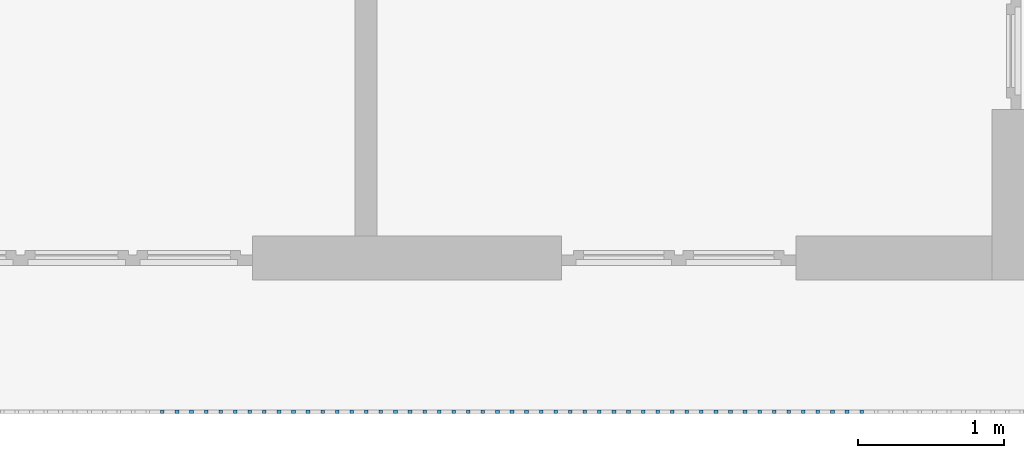
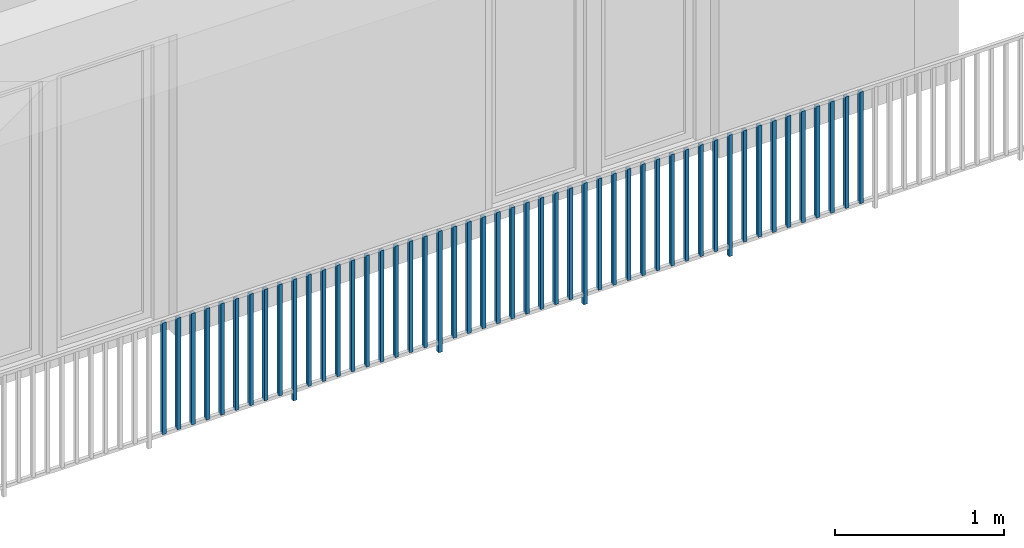
# One storey, part 42 of 54: 49 building element parts, 1 element without a shape of its own.
"""IFC4 building model written with IfcOpenShell, lengths in metres."""

from ifc_helpers import new_model, entity, si_unit, converted_unit, derived_unit, direction, frame, origin_with_axes, place, context, subcontext, project, spatial, polygons, material, type_object, element, aggregate, save


model = new_model("IFC4")

# Units and contexts
model_context = context("Model", 3, precision=1e-05, world=origin_with_axes(), true_north=direction((0.0, 1.0)))
body_context = subcontext(model_context, "Body", "Model", "MODEL_VIEW")
ifc_project = project(units=[si_unit("LENGTHUNIT", "METRE"), si_unit("AREAUNIT", "SQUARE_METRE"), si_unit("VOLUMEUNIT", "CUBIC_METRE"), converted_unit("PLANEANGLEUNIT", "DEGREE", entity("IfcPlaneAngleMeasure", 0.0174532925199), si_unit("PLANEANGLEUNIT", "RADIAN"), dimensions=[0, 0, 0, 0, 0, 0, 0]), converted_unit("TIMEUNIT", "Year", entity("IfcTimeMeasure", 31556926.0), si_unit("TIMEUNIT", "SECOND"), dimensions=[0, 0, 1, 0, 0, 0, 0]), si_unit("MASSUNIT", "GRAM", prefix="KILO"), si_unit("THERMODYNAMICTEMPERATUREUNIT", "DEGREE_CELSIUS"), si_unit("LUMINOUSINTENSITYUNIT", "LUMEN"), si_unit("ENERGYUNIT", "JOULE", prefix="MEGA"), derived_unit("THERMALCONDUCTANCEUNIT", [(si_unit("POWERUNIT", "WATT"), 1), (si_unit("LENGTHUNIT", "METRE"), -1), (si_unit("THERMODYNAMICTEMPERATUREUNIT", "KELVIN"), -1)]), derived_unit("SPECIFICHEATCAPACITYUNIT", [(si_unit("ENERGYUNIT", "JOULE"), 1), (si_unit("MASSUNIT", "GRAM", prefix="KILO"), -1), (si_unit("THERMODYNAMICTEMPERATUREUNIT", "KELVIN"), -1)]), derived_unit("MASSDENSITYUNIT", [(si_unit("MASSUNIT", "GRAM", prefix="KILO"), 1), (si_unit("VOLUMEUNIT", "CUBIC_METRE"), -1)])], contexts=[model_context])

# Site, building, storey, space
site_placement = place(None, origin_with_axes())
site = spatial("IfcSite", under=ifc_project, at=site_placement, CompositionType="ELEMENT")
building_placement = place(site_placement, origin_with_axes())
building = spatial("IfcBuilding", under=site, at=building_placement, CompositionType="ELEMENT")
storey_placement = place(building_placement, frame((0.0, 0.0, 6.29), z_axis=(0.0, 0.0, 1.0), x_axis=(1.0, 0.0, 0.0)))
storey = spatial("IfcBuildingStorey", under=building, at=storey_placement, Name="2. Geschoss", CompositionType="ELEMENT", Elevation=6.29)
space_placement = place(storey_placement, frame((10.2378006196, 9.82118769833, 0.0), z_axis=(0.0, 0.0, 1.0), x_axis=(-1.0, 0.0, 0.0)))
space = spatial("IfcSpace", under=storey, at=space_placement, CompositionType="ELEMENT", PredefinedType="EXTERNAL")

# Railing, building element parts
railing_type = type_object("IfcRailingType", PredefinedType="NOTDEFINED")
railing_placement = place(space_placement, frame((0.0, -7.06315681498e-08, 0.0), z_axis=(0.0, 0.0, 1.0), x_axis=(-1.0, 0.0, 0.0)))
railing = element("IfcRailing", 1, at=railing_placement, inside=space, type_object=railing_type, PredefinedType="NOTDEFINED")
ifc_material = material()
building_element_part_1_placement = place(railing_placement, origin_with_axes())
building_element_part_1 = element("IfcBuildingElementPart", 2, at=building_element_part_1_placement, material=ifc_material, PredefinedType="NOTDEFINED", context=body_context, shape_type="Tessellation", body=[
    polygons([(-6.8515, -20.6625, 0.07), (-6.8515, -20.6375, 0.07), (-6.8515, -20.6375, 0.8775), (-6.8515, -20.6625, 0.8775), (-6.8765, -20.6625, 0.07), (-6.8765, -20.6375, 0.07), (-6.8765, -20.6375, 0.8775), (-6.8765, -20.6625, 0.8775)], [[[1, 2, 3, 4]], [[1, 5, 6, 2]], [[2, 6, 7, 3]], [[4, 3, 7, 8]], [[5, 1, 4, 8]], [[6, 5, 8, 7]]], closed=True),
])
building_element_part_2_placement = place(railing_placement, origin_with_axes())
building_element_part_2 = element("IfcBuildingElementPart", 3, at=building_element_part_2_placement, material=ifc_material, PredefinedType="NOTDEFINED", context=body_context, shape_type="Tessellation", body=[
    polygons([(-6.75202173913, -20.6625, 0.07), (-6.75202173913, -20.6375, 0.07), (-6.75202173913, -20.6375, 0.8775), (-6.75202173913, -20.6625, 0.8775), (-6.77702173913, -20.6625, 0.07), (-6.77702173913, -20.6375, 0.07), (-6.77702173913, -20.6375, 0.8775), (-6.77702173913, -20.6625, 0.8775)], [[[1, 2, 3, 4]], [[1, 5, 6, 2]], [[2, 6, 7, 3]], [[4, 3, 7, 8]], [[5, 1, 4, 8]], [[6, 5, 8, 7]]], closed=True),
])
building_element_part_3_placement = place(railing_placement, origin_with_axes())
building_element_part_3 = element("IfcBuildingElementPart", 4, at=building_element_part_3_placement, material=ifc_material, PredefinedType="NOTDEFINED", context=body_context, shape_type="Tessellation", body=[
    polygons([(-6.65254347826, -20.6625, 0.07), (-6.65254347826, -20.6375, 0.07), (-6.65254347826, -20.6375, 0.8775), (-6.65254347826, -20.6625, 0.8775), (-6.67754347826, -20.6625, 0.07), (-6.67754347826, -20.6375, 0.07), (-6.67754347826, -20.6375, 0.8775), (-6.67754347826, -20.6625, 0.8775)], [[[1, 2, 3, 4]], [[1, 5, 6, 2]], [[2, 6, 7, 3]], [[4, 3, 7, 8]], [[5, 1, 4, 8]], [[6, 5, 8, 7]]], closed=True),
])
building_element_part_4_placement = place(railing_placement, origin_with_axes())
building_element_part_4 = element("IfcBuildingElementPart", 5, at=building_element_part_4_placement, material=ifc_material, PredefinedType="NOTDEFINED", context=body_context, shape_type="Tessellation", body=[
    polygons([(-6.55306521739, -20.6625, 0.07), (-6.55306521739, -20.6375, 0.07), (-6.55306521739, -20.6375, 0.8775), (-6.55306521739, -20.6625, 0.8775), (-6.57806521739, -20.6625, 0.07), (-6.57806521739, -20.6375, 0.07), (-6.57806521739, -20.6375, 0.8775), (-6.57806521739, -20.6625, 0.8775)], [[[1, 2, 3, 4]], [[1, 5, 6, 2]], [[2, 6, 7, 3]], [[4, 3, 7, 8]], [[5, 1, 4, 8]], [[6, 5, 8, 7]]], closed=True),
])
building_element_part_5_placement = place(railing_placement, origin_with_axes())
building_element_part_5 = element("IfcBuildingElementPart", 6, at=building_element_part_5_placement, material=ifc_material, PredefinedType="NOTDEFINED", context=body_context, shape_type="Tessellation", body=[
    polygons([(-6.45358695652, -20.6625, 0.07), (-6.45358695652, -20.6375, 0.07), (-6.45358695652, -20.6375, 0.8775), (-6.45358695652, -20.6625, 0.8775), (-6.47858695652, -20.6625, 0.07), (-6.47858695652, -20.6375, 0.07), (-6.47858695652, -20.6375, 0.8775), (-6.47858695652, -20.6625, 0.8775)], [[[1, 2, 3, 4]], [[1, 5, 6, 2]], [[2, 6, 7, 3]], [[4, 3, 7, 8]], [[5, 1, 4, 8]], [[6, 5, 8, 7]]], closed=True),
])
building_element_part_6_placement = place(railing_placement, origin_with_axes())
building_element_part_6 = element("IfcBuildingElementPart", 7, at=building_element_part_6_placement, material=ifc_material, PredefinedType="NOTDEFINED", context=body_context, shape_type="Tessellation", body=[
    polygons([(-6.35410869565, -20.6625, 0.07), (-6.35410869565, -20.6375, 0.07), (-6.35410869565, -20.6375, 0.8775), (-6.35410869565, -20.6625, 0.8775), (-6.37910869565, -20.6625, 0.07), (-6.37910869565, -20.6375, 0.07), (-6.37910869565, -20.6375, 0.8775), (-6.37910869565, -20.6625, 0.8775)], [[[1, 2, 3, 4]], [[1, 5, 6, 2]], [[2, 6, 7, 3]], [[4, 3, 7, 8]], [[5, 1, 4, 8]], [[6, 5, 8, 7]]], closed=True),
])
building_element_part_7_placement = place(railing_placement, origin_with_axes())
building_element_part_7 = element("IfcBuildingElementPart", 8, at=building_element_part_7_placement, material=ifc_material, PredefinedType="NOTDEFINED", context=body_context, shape_type="Tessellation", body=[
    polygons([(-6.25463043478, -20.6625, 0.07), (-6.25463043478, -20.6375, 0.07), (-6.25463043478, -20.6375, 0.8775), (-6.25463043478, -20.6625, 0.8775), (-6.27963043478, -20.6625, 0.07), (-6.27963043478, -20.6375, 0.07), (-6.27963043478, -20.6375, 0.8775), (-6.27963043478, -20.6625, 0.8775)], [[[1, 2, 3, 4]], [[1, 5, 6, 2]], [[2, 6, 7, 3]], [[4, 3, 7, 8]], [[5, 1, 4, 8]], [[6, 5, 8, 7]]], closed=True),
])
building_element_part_8_placement = place(railing_placement, origin_with_axes())
building_element_part_8 = element("IfcBuildingElementPart", 9, at=building_element_part_8_placement, material=ifc_material, PredefinedType="NOTDEFINED", context=body_context, shape_type="Tessellation", body=[
    polygons([(-6.15515217391, -20.6625, 0.07), (-6.15515217391, -20.6375, 0.07), (-6.15515217391, -20.6375, 0.8775), (-6.15515217391, -20.6625, 0.8775), (-6.18015217391, -20.6625, 0.07), (-6.18015217391, -20.6375, 0.07), (-6.18015217391, -20.6375, 0.8775), (-6.18015217391, -20.6625, 0.8775)], [[[1, 2, 3, 4]], [[1, 5, 6, 2]], [[2, 6, 7, 3]], [[4, 3, 7, 8]], [[5, 1, 4, 8]], [[6, 5, 8, 7]]], closed=True),
])
building_element_part_9_placement = place(railing_placement, origin_with_axes())
building_element_part_9 = element("IfcBuildingElementPart", 10, at=building_element_part_9_placement, material=ifc_material, PredefinedType="NOTDEFINED", context=body_context, shape_type="Tessellation", body=[
    polygons([(-6.05567391304, -20.6625, 0.07), (-6.05567391304, -20.6375, 0.07), (-6.05567391304, -20.6375, 0.8775), (-6.05567391304, -20.6625, 0.8775), (-6.08067391304, -20.6625, 0.07), (-6.08067391304, -20.6375, 0.07), (-6.08067391304, -20.6375, 0.8775), (-6.08067391304, -20.6625, 0.8775)], [[[1, 2, 3, 4]], [[1, 5, 6, 2]], [[2, 6, 7, 3]], [[4, 3, 7, 8]], [[5, 1, 4, 8]], [[6, 5, 8, 7]]], closed=True),
])
building_element_part_10_placement = place(railing_placement, origin_with_axes())
building_element_part_10 = element("IfcBuildingElementPart", 11, at=building_element_part_10_placement, material=ifc_material, PredefinedType="NOTDEFINED", context=body_context, shape_type="Tessellation", body=[
    polygons([(-5.95619565217, -20.6625, 0.0), (-5.95619565217, -20.6375, 0.0), (-5.95619565217, -20.6375, 0.88), (-5.95619565217, -20.6625, 0.88), (-5.98119565217, -20.6625, 0.0), (-5.98119565217, -20.6375, 0.0), (-5.98119565217, -20.6375, 0.88), (-5.98119565217, -20.6625, 0.88)], [[[1, 2, 3, 4]], [[1, 5, 6, 2]], [[2, 6, 7, 3]], [[4, 3, 7, 8]], [[5, 1, 4, 8]], [[6, 5, 8, 7]]], closed=True),
])
building_element_part_11_placement = place(railing_placement, origin_with_axes())
building_element_part_11 = element("IfcBuildingElementPart", 12, at=building_element_part_11_placement, material=ifc_material, PredefinedType="NOTDEFINED", context=body_context, shape_type="Tessellation", body=[
    polygons([(-5.8567173913, -20.6625, 0.07), (-5.8567173913, -20.6375, 0.07), (-5.8567173913, -20.6375, 0.8775), (-5.8567173913, -20.6625, 0.8775), (-5.8817173913, -20.6625, 0.07), (-5.8817173913, -20.6375, 0.07), (-5.8817173913, -20.6375, 0.8775), (-5.8817173913, -20.6625, 0.8775)], [[[1, 2, 3, 4]], [[1, 5, 6, 2]], [[2, 6, 7, 3]], [[4, 3, 7, 8]], [[5, 1, 4, 8]], [[6, 5, 8, 7]]], closed=True),
])
building_element_part_12_placement = place(railing_placement, origin_with_axes())
building_element_part_12 = element("IfcBuildingElementPart", 13, at=building_element_part_12_placement, material=ifc_material, PredefinedType="NOTDEFINED", context=body_context, shape_type="Tessellation", body=[
    polygons([(-5.75723913043, -20.6625, 0.07), (-5.75723913043, -20.6375, 0.07), (-5.75723913043, -20.6375, 0.8775), (-5.75723913043, -20.6625, 0.8775), (-5.78223913043, -20.6625, 0.07), (-5.78223913043, -20.6375, 0.07), (-5.78223913043, -20.6375, 0.8775), (-5.78223913043, -20.6625, 0.8775)], [[[1, 2, 3, 4]], [[1, 5, 6, 2]], [[2, 6, 7, 3]], [[4, 3, 7, 8]], [[5, 1, 4, 8]], [[6, 5, 8, 7]]], closed=True),
])
building_element_part_13_placement = place(railing_placement, origin_with_axes())
building_element_part_13 = element("IfcBuildingElementPart", 14, at=building_element_part_13_placement, material=ifc_material, PredefinedType="NOTDEFINED", context=body_context, shape_type="Tessellation", body=[
    polygons([(-5.65776086957, -20.6625, 0.07), (-5.65776086957, -20.6375, 0.07), (-5.65776086957, -20.6375, 0.8775), (-5.65776086957, -20.6625, 0.8775), (-5.68276086957, -20.6625, 0.07), (-5.68276086957, -20.6375, 0.07), (-5.68276086957, -20.6375, 0.8775), (-5.68276086957, -20.6625, 0.8775)], [[[1, 2, 3, 4]], [[1, 5, 6, 2]], [[2, 6, 7, 3]], [[4, 3, 7, 8]], [[5, 1, 4, 8]], [[6, 5, 8, 7]]], closed=True),
])
building_element_part_14_placement = place(railing_placement, origin_with_axes())
building_element_part_14 = element("IfcBuildingElementPart", 15, at=building_element_part_14_placement, material=ifc_material, PredefinedType="NOTDEFINED", context=body_context, shape_type="Tessellation", body=[
    polygons([(-5.5582826087, -20.6625, 0.07), (-5.5582826087, -20.6375, 0.07), (-5.5582826087, -20.6375, 0.8775), (-5.5582826087, -20.6625, 0.8775), (-5.5832826087, -20.6625, 0.07), (-5.5832826087, -20.6375, 0.07), (-5.5832826087, -20.6375, 0.8775), (-5.5832826087, -20.6625, 0.8775)], [[[1, 2, 3, 4]], [[1, 5, 6, 2]], [[2, 6, 7, 3]], [[4, 3, 7, 8]], [[5, 1, 4, 8]], [[6, 5, 8, 7]]], closed=True),
])
building_element_part_15_placement = place(railing_placement, origin_with_axes())
building_element_part_15 = element("IfcBuildingElementPart", 16, at=building_element_part_15_placement, material=ifc_material, PredefinedType="NOTDEFINED", context=body_context, shape_type="Tessellation", body=[
    polygons([(-5.45880434783, -20.6625, 0.07), (-5.45880434783, -20.6375, 0.07), (-5.45880434783, -20.6375, 0.8775), (-5.45880434783, -20.6625, 0.8775), (-5.48380434783, -20.6625, 0.07), (-5.48380434783, -20.6375, 0.07), (-5.48380434783, -20.6375, 0.8775), (-5.48380434783, -20.6625, 0.8775)], [[[1, 2, 3, 4]], [[1, 5, 6, 2]], [[2, 6, 7, 3]], [[4, 3, 7, 8]], [[5, 1, 4, 8]], [[6, 5, 8, 7]]], closed=True),
])
building_element_part_16_placement = place(railing_placement, origin_with_axes())
building_element_part_16 = element("IfcBuildingElementPart", 17, at=building_element_part_16_placement, material=ifc_material, PredefinedType="NOTDEFINED", context=body_context, shape_type="Tessellation", body=[
    polygons([(-5.35932608696, -20.6625, 0.07), (-5.35932608696, -20.6375, 0.07), (-5.35932608696, -20.6375, 0.8775), (-5.35932608696, -20.6625, 0.8775), (-5.38432608696, -20.6625, 0.07), (-5.38432608696, -20.6375, 0.07), (-5.38432608696, -20.6375, 0.8775), (-5.38432608696, -20.6625, 0.8775)], [[[1, 2, 3, 4]], [[1, 5, 6, 2]], [[2, 6, 7, 3]], [[4, 3, 7, 8]], [[5, 1, 4, 8]], [[6, 5, 8, 7]]], closed=True),
])
building_element_part_17_placement = place(railing_placement, origin_with_axes())
building_element_part_17 = element("IfcBuildingElementPart", 18, at=building_element_part_17_placement, material=ifc_material, PredefinedType="NOTDEFINED", context=body_context, shape_type="Tessellation", body=[
    polygons([(-5.25984782609, -20.6625, 0.07), (-5.25984782609, -20.6375, 0.07), (-5.25984782609, -20.6375, 0.8775), (-5.25984782609, -20.6625, 0.8775), (-5.28484782609, -20.6625, 0.07), (-5.28484782609, -20.6375, 0.07), (-5.28484782609, -20.6375, 0.8775), (-5.28484782609, -20.6625, 0.8775)], [[[1, 2, 3, 4]], [[1, 5, 6, 2]], [[2, 6, 7, 3]], [[4, 3, 7, 8]], [[5, 1, 4, 8]], [[6, 5, 8, 7]]], closed=True),
])
building_element_part_18_placement = place(railing_placement, origin_with_axes())
building_element_part_18 = element("IfcBuildingElementPart", 19, at=building_element_part_18_placement, material=ifc_material, PredefinedType="NOTDEFINED", context=body_context, shape_type="Tessellation", body=[
    polygons([(-5.16036956522, -20.6625, 0.07), (-5.16036956522, -20.6375, 0.07), (-5.16036956522, -20.6375, 0.8775), (-5.16036956522, -20.6625, 0.8775), (-5.18536956522, -20.6625, 0.07), (-5.18536956522, -20.6375, 0.07), (-5.18536956522, -20.6375, 0.8775), (-5.18536956522, -20.6625, 0.8775)], [[[1, 2, 3, 4]], [[1, 5, 6, 2]], [[2, 6, 7, 3]], [[4, 3, 7, 8]], [[5, 1, 4, 8]], [[6, 5, 8, 7]]], closed=True),
])
building_element_part_19_placement = place(railing_placement, origin_with_axes())
building_element_part_19 = element("IfcBuildingElementPart", 20, at=building_element_part_19_placement, material=ifc_material, PredefinedType="NOTDEFINED", context=body_context, shape_type="Tessellation", body=[
    polygons([(-5.06089130435, -20.6625, 0.07), (-5.06089130435, -20.6375, 0.07), (-5.06089130435, -20.6375, 0.8775), (-5.06089130435, -20.6625, 0.8775), (-5.08589130435, -20.6625, 0.07), (-5.08589130435, -20.6375, 0.07), (-5.08589130435, -20.6375, 0.8775), (-5.08589130435, -20.6625, 0.8775)], [[[1, 2, 3, 4]], [[1, 5, 6, 2]], [[2, 6, 7, 3]], [[4, 3, 7, 8]], [[5, 1, 4, 8]], [[6, 5, 8, 7]]], closed=True),
])
building_element_part_20_placement = place(railing_placement, origin_with_axes())
building_element_part_20 = element("IfcBuildingElementPart", 21, at=building_element_part_20_placement, material=ifc_material, PredefinedType="NOTDEFINED", context=body_context, shape_type="Tessellation", body=[
    polygons([(-4.96141304348, -20.6625, 0.0), (-4.96141304348, -20.6375, 0.0), (-4.96141304348, -20.6375, 0.88), (-4.96141304348, -20.6625, 0.88), (-4.98641304348, -20.6625, 0.0), (-4.98641304348, -20.6375, 0.0), (-4.98641304348, -20.6375, 0.88), (-4.98641304348, -20.6625, 0.88)], [[[1, 2, 3, 4]], [[1, 5, 6, 2]], [[2, 6, 7, 3]], [[4, 3, 7, 8]], [[5, 1, 4, 8]], [[6, 5, 8, 7]]], closed=True),
])
building_element_part_21_placement = place(railing_placement, origin_with_axes())
building_element_part_21 = element("IfcBuildingElementPart", 22, at=building_element_part_21_placement, material=ifc_material, PredefinedType="NOTDEFINED", context=body_context, shape_type="Tessellation", body=[
    polygons([(-4.86193478261, -20.6625, 0.07), (-4.86193478261, -20.6375, 0.07), (-4.86193478261, -20.6375, 0.8775), (-4.86193478261, -20.6625, 0.8775), (-4.88693478261, -20.6625, 0.07), (-4.88693478261, -20.6375, 0.07), (-4.88693478261, -20.6375, 0.8775), (-4.88693478261, -20.6625, 0.8775)], [[[1, 2, 3, 4]], [[1, 5, 6, 2]], [[2, 6, 7, 3]], [[4, 3, 7, 8]], [[5, 1, 4, 8]], [[6, 5, 8, 7]]], closed=True),
])
building_element_part_22_placement = place(railing_placement, origin_with_axes())
building_element_part_22 = element("IfcBuildingElementPart", 23, at=building_element_part_22_placement, material=ifc_material, PredefinedType="NOTDEFINED", context=body_context, shape_type="Tessellation", body=[
    polygons([(-4.76245652174, -20.6625, 0.07), (-4.76245652174, -20.6375, 0.07), (-4.76245652174, -20.6375, 0.8775), (-4.76245652174, -20.6625, 0.8775), (-4.78745652174, -20.6625, 0.07), (-4.78745652174, -20.6375, 0.07), (-4.78745652174, -20.6375, 0.8775), (-4.78745652174, -20.6625, 0.8775)], [[[1, 2, 3, 4]], [[1, 5, 6, 2]], [[2, 6, 7, 3]], [[4, 3, 7, 8]], [[5, 1, 4, 8]], [[6, 5, 8, 7]]], closed=True),
])
building_element_part_23_placement = place(railing_placement, origin_with_axes())
building_element_part_23 = element("IfcBuildingElementPart", 24, at=building_element_part_23_placement, material=ifc_material, PredefinedType="NOTDEFINED", context=body_context, shape_type="Tessellation", body=[
    polygons([(-4.66297826087, -20.6625, 0.07), (-4.66297826087, -20.6375, 0.07), (-4.66297826087, -20.6375, 0.8775), (-4.66297826087, -20.6625, 0.8775), (-4.68797826087, -20.6625, 0.07), (-4.68797826087, -20.6375, 0.07), (-4.68797826087, -20.6375, 0.8775), (-4.68797826087, -20.6625, 0.8775)], [[[1, 2, 3, 4]], [[1, 5, 6, 2]], [[2, 6, 7, 3]], [[4, 3, 7, 8]], [[5, 1, 4, 8]], [[6, 5, 8, 7]]], closed=True),
])
building_element_part_24_placement = place(railing_placement, origin_with_axes())
building_element_part_24 = element("IfcBuildingElementPart", 25, at=building_element_part_24_placement, material=ifc_material, PredefinedType="NOTDEFINED", context=body_context, shape_type="Tessellation", body=[
    polygons([(-4.5635, -20.6625, 0.07), (-4.5635, -20.6375, 0.07), (-4.5635, -20.6375, 0.8775), (-4.5635, -20.6625, 0.8775), (-4.5885, -20.6625, 0.07), (-4.5885, -20.6375, 0.07), (-4.5885, -20.6375, 0.8775), (-4.5885, -20.6625, 0.8775)], [[[1, 2, 3, 4]], [[1, 5, 6, 2]], [[2, 6, 7, 3]], [[4, 3, 7, 8]], [[5, 1, 4, 8]], [[6, 5, 8, 7]]], closed=True),
])
building_element_part_25_placement = place(railing_placement, origin_with_axes())
building_element_part_25 = element("IfcBuildingElementPart", 26, at=building_element_part_25_placement, material=ifc_material, PredefinedType="NOTDEFINED", context=body_context, shape_type="Tessellation", body=[
    polygons([(-4.46402173913, -20.6625, 0.07), (-4.46402173913, -20.6375, 0.07), (-4.46402173913, -20.6375, 0.8775), (-4.46402173913, -20.6625, 0.8775), (-4.48902173913, -20.6625, 0.07), (-4.48902173913, -20.6375, 0.07), (-4.48902173913, -20.6375, 0.8775), (-4.48902173913, -20.6625, 0.8775)], [[[1, 2, 3, 4]], [[1, 5, 6, 2]], [[2, 6, 7, 3]], [[4, 3, 7, 8]], [[5, 1, 4, 8]], [[6, 5, 8, 7]]], closed=True),
])
building_element_part_26_placement = place(railing_placement, origin_with_axes())
building_element_part_26 = element("IfcBuildingElementPart", 27, at=building_element_part_26_placement, material=ifc_material, PredefinedType="NOTDEFINED", context=body_context, shape_type="Tessellation", body=[
    polygons([(-4.36454347826, -20.6625, 0.07), (-4.36454347826, -20.6375, 0.07), (-4.36454347826, -20.6375, 0.8775), (-4.36454347826, -20.6625, 0.8775), (-4.38954347826, -20.6625, 0.07), (-4.38954347826, -20.6375, 0.07), (-4.38954347826, -20.6375, 0.8775), (-4.38954347826, -20.6625, 0.8775)], [[[1, 2, 3, 4]], [[1, 5, 6, 2]], [[2, 6, 7, 3]], [[4, 3, 7, 8]], [[5, 1, 4, 8]], [[6, 5, 8, 7]]], closed=True),
])
building_element_part_27_placement = place(railing_placement, origin_with_axes())
building_element_part_27 = element("IfcBuildingElementPart", 28, at=building_element_part_27_placement, material=ifc_material, PredefinedType="NOTDEFINED", context=body_context, shape_type="Tessellation", body=[
    polygons([(-4.26506521739, -20.6625, 0.07), (-4.26506521739, -20.6375, 0.07), (-4.26506521739, -20.6375, 0.8775), (-4.26506521739, -20.6625, 0.8775), (-4.29006521739, -20.6625, 0.07), (-4.29006521739, -20.6375, 0.07), (-4.29006521739, -20.6375, 0.8775), (-4.29006521739, -20.6625, 0.8775)], [[[1, 2, 3, 4]], [[1, 5, 6, 2]], [[2, 6, 7, 3]], [[4, 3, 7, 8]], [[5, 1, 4, 8]], [[6, 5, 8, 7]]], closed=True),
])
building_element_part_28_placement = place(railing_placement, origin_with_axes())
building_element_part_28 = element("IfcBuildingElementPart", 29, at=building_element_part_28_placement, material=ifc_material, PredefinedType="NOTDEFINED", context=body_context, shape_type="Tessellation", body=[
    polygons([(-4.16558695652, -20.6625, 0.07), (-4.16558695652, -20.6375, 0.07), (-4.16558695652, -20.6375, 0.8775), (-4.16558695652, -20.6625, 0.8775), (-4.19058695652, -20.6625, 0.07), (-4.19058695652, -20.6375, 0.07), (-4.19058695652, -20.6375, 0.8775), (-4.19058695652, -20.6625, 0.8775)], [[[1, 2, 3, 4]], [[1, 5, 6, 2]], [[2, 6, 7, 3]], [[4, 3, 7, 8]], [[5, 1, 4, 8]], [[6, 5, 8, 7]]], closed=True),
])
building_element_part_29_placement = place(railing_placement, origin_with_axes())
building_element_part_29 = element("IfcBuildingElementPart", 30, at=building_element_part_29_placement, material=ifc_material, PredefinedType="NOTDEFINED", context=body_context, shape_type="Tessellation", body=[
    polygons([(-4.06610869565, -20.6625, 0.07), (-4.06610869565, -20.6375, 0.07), (-4.06610869565, -20.6375, 0.8775), (-4.06610869565, -20.6625, 0.8775), (-4.09110869565, -20.6625, 0.07), (-4.09110869565, -20.6375, 0.07), (-4.09110869565, -20.6375, 0.8775), (-4.09110869565, -20.6625, 0.8775)], [[[1, 2, 3, 4]], [[1, 5, 6, 2]], [[2, 6, 7, 3]], [[4, 3, 7, 8]], [[5, 1, 4, 8]], [[6, 5, 8, 7]]], closed=True),
])
building_element_part_30_placement = place(railing_placement, origin_with_axes())
building_element_part_30 = element("IfcBuildingElementPart", 31, at=building_element_part_30_placement, material=ifc_material, PredefinedType="NOTDEFINED", context=body_context, shape_type="Tessellation", body=[
    polygons([(-3.96663043478, -20.6625, 0.0), (-3.96663043478, -20.6375, 0.0), (-3.96663043478, -20.6375, 0.88), (-3.96663043478, -20.6625, 0.88), (-3.99163043478, -20.6625, 0.0), (-3.99163043478, -20.6375, 0.0), (-3.99163043478, -20.6375, 0.88), (-3.99163043478, -20.6625, 0.88)], [[[1, 2, 3, 4]], [[1, 5, 6, 2]], [[2, 6, 7, 3]], [[4, 3, 7, 8]], [[5, 1, 4, 8]], [[6, 5, 8, 7]]], closed=True),
])
building_element_part_31_placement = place(railing_placement, origin_with_axes())
building_element_part_31 = element("IfcBuildingElementPart", 32, at=building_element_part_31_placement, material=ifc_material, PredefinedType="NOTDEFINED", context=body_context, shape_type="Tessellation", body=[
    polygons([(-3.86715217391, -20.6625, 0.07), (-3.86715217391, -20.6375, 0.07), (-3.86715217391, -20.6375, 0.8775), (-3.86715217391, -20.6625, 0.8775), (-3.89215217391, -20.6625, 0.07), (-3.89215217391, -20.6375, 0.07), (-3.89215217391, -20.6375, 0.8775), (-3.89215217391, -20.6625, 0.8775)], [[[1, 2, 3, 4]], [[1, 5, 6, 2]], [[2, 6, 7, 3]], [[4, 3, 7, 8]], [[5, 1, 4, 8]], [[6, 5, 8, 7]]], closed=True),
])
building_element_part_32_placement = place(railing_placement, origin_with_axes())
building_element_part_32 = element("IfcBuildingElementPart", 33, at=building_element_part_32_placement, material=ifc_material, PredefinedType="NOTDEFINED", context=body_context, shape_type="Tessellation", body=[
    polygons([(-3.76767391304, -20.6625, 0.07), (-3.76767391304, -20.6375, 0.07), (-3.76767391304, -20.6375, 0.8775), (-3.76767391304, -20.6625, 0.8775), (-3.79267391304, -20.6625, 0.07), (-3.79267391304, -20.6375, 0.07), (-3.79267391304, -20.6375, 0.8775), (-3.79267391304, -20.6625, 0.8775)], [[[1, 2, 3, 4]], [[1, 5, 6, 2]], [[2, 6, 7, 3]], [[4, 3, 7, 8]], [[5, 1, 4, 8]], [[6, 5, 8, 7]]], closed=True),
])
building_element_part_33_placement = place(railing_placement, origin_with_axes())
building_element_part_33 = element("IfcBuildingElementPart", 34, at=building_element_part_33_placement, material=ifc_material, PredefinedType="NOTDEFINED", context=body_context, shape_type="Tessellation", body=[
    polygons([(-3.66819565217, -20.6625, 0.07), (-3.66819565217, -20.6375, 0.07), (-3.66819565217, -20.6375, 0.8775), (-3.66819565217, -20.6625, 0.8775), (-3.69319565217, -20.6625, 0.07), (-3.69319565217, -20.6375, 0.07), (-3.69319565217, -20.6375, 0.8775), (-3.69319565217, -20.6625, 0.8775)], [[[1, 2, 3, 4]], [[1, 5, 6, 2]], [[2, 6, 7, 3]], [[4, 3, 7, 8]], [[5, 1, 4, 8]], [[6, 5, 8, 7]]], closed=True),
])
building_element_part_34_placement = place(railing_placement, origin_with_axes())
building_element_part_34 = element("IfcBuildingElementPart", 35, at=building_element_part_34_placement, material=ifc_material, PredefinedType="NOTDEFINED", context=body_context, shape_type="Tessellation", body=[
    polygons([(-3.5687173913, -20.6625, 0.07), (-3.5687173913, -20.6375, 0.07), (-3.5687173913, -20.6375, 0.8775), (-3.5687173913, -20.6625, 0.8775), (-3.5937173913, -20.6625, 0.07), (-3.5937173913, -20.6375, 0.07), (-3.5937173913, -20.6375, 0.8775), (-3.5937173913, -20.6625, 0.8775)], [[[1, 2, 3, 4]], [[1, 5, 6, 2]], [[2, 6, 7, 3]], [[4, 3, 7, 8]], [[5, 1, 4, 8]], [[6, 5, 8, 7]]], closed=True),
])
building_element_part_35_placement = place(railing_placement, origin_with_axes())
building_element_part_35 = element("IfcBuildingElementPart", 36, at=building_element_part_35_placement, material=ifc_material, PredefinedType="NOTDEFINED", context=body_context, shape_type="Tessellation", body=[
    polygons([(-3.46923913043, -20.6625, 0.07), (-3.46923913043, -20.6375, 0.07), (-3.46923913043, -20.6375, 0.8775), (-3.46923913043, -20.6625, 0.8775), (-3.49423913043, -20.6625, 0.07), (-3.49423913043, -20.6375, 0.07), (-3.49423913043, -20.6375, 0.8775), (-3.49423913043, -20.6625, 0.8775)], [[[1, 2, 3, 4]], [[1, 5, 6, 2]], [[2, 6, 7, 3]], [[4, 3, 7, 8]], [[5, 1, 4, 8]], [[6, 5, 8, 7]]], closed=True),
])
building_element_part_36_placement = place(railing_placement, origin_with_axes())
building_element_part_36 = element("IfcBuildingElementPart", 37, at=building_element_part_36_placement, material=ifc_material, PredefinedType="NOTDEFINED", context=body_context, shape_type="Tessellation", body=[
    polygons([(-3.36976086957, -20.6625, 0.07), (-3.36976086957, -20.6375, 0.07), (-3.36976086957, -20.6375, 0.8775), (-3.36976086957, -20.6625, 0.8775), (-3.39476086957, -20.6625, 0.07), (-3.39476086957, -20.6375, 0.07), (-3.39476086957, -20.6375, 0.8775), (-3.39476086957, -20.6625, 0.8775)], [[[1, 2, 3, 4]], [[1, 5, 6, 2]], [[2, 6, 7, 3]], [[4, 3, 7, 8]], [[5, 1, 4, 8]], [[6, 5, 8, 7]]], closed=True),
])
building_element_part_37_placement = place(railing_placement, origin_with_axes())
building_element_part_37 = element("IfcBuildingElementPart", 38, at=building_element_part_37_placement, material=ifc_material, PredefinedType="NOTDEFINED", context=body_context, shape_type="Tessellation", body=[
    polygons([(-3.2702826087, -20.6625, 0.07), (-3.2702826087, -20.6375, 0.07), (-3.2702826087, -20.6375, 0.8775), (-3.2702826087, -20.6625, 0.8775), (-3.2952826087, -20.6625, 0.07), (-3.2952826087, -20.6375, 0.07), (-3.2952826087, -20.6375, 0.8775), (-3.2952826087, -20.6625, 0.8775)], [[[1, 2, 3, 4]], [[1, 5, 6, 2]], [[2, 6, 7, 3]], [[4, 3, 7, 8]], [[5, 1, 4, 8]], [[6, 5, 8, 7]]], closed=True),
])
building_element_part_38_placement = place(railing_placement, origin_with_axes())
building_element_part_38 = element("IfcBuildingElementPart", 39, at=building_element_part_38_placement, material=ifc_material, PredefinedType="NOTDEFINED", context=body_context, shape_type="Tessellation", body=[
    polygons([(-3.17080434783, -20.6625, 0.07), (-3.17080434783, -20.6375, 0.07), (-3.17080434783, -20.6375, 0.8775), (-3.17080434783, -20.6625, 0.8775), (-3.19580434783, -20.6625, 0.07), (-3.19580434783, -20.6375, 0.07), (-3.19580434783, -20.6375, 0.8775), (-3.19580434783, -20.6625, 0.8775)], [[[1, 2, 3, 4]], [[1, 5, 6, 2]], [[2, 6, 7, 3]], [[4, 3, 7, 8]], [[5, 1, 4, 8]], [[6, 5, 8, 7]]], closed=True),
])
building_element_part_39_placement = place(railing_placement, origin_with_axes())
building_element_part_39 = element("IfcBuildingElementPart", 40, at=building_element_part_39_placement, material=ifc_material, PredefinedType="NOTDEFINED", context=body_context, shape_type="Tessellation", body=[
    polygons([(-3.07132608696, -20.6625, 0.07), (-3.07132608696, -20.6375, 0.07), (-3.07132608696, -20.6375, 0.8775), (-3.07132608696, -20.6625, 0.8775), (-3.09632608696, -20.6625, 0.07), (-3.09632608696, -20.6375, 0.07), (-3.09632608696, -20.6375, 0.8775), (-3.09632608696, -20.6625, 0.8775)], [[[1, 2, 3, 4]], [[1, 5, 6, 2]], [[2, 6, 7, 3]], [[4, 3, 7, 8]], [[5, 1, 4, 8]], [[6, 5, 8, 7]]], closed=True),
])
building_element_part_40_placement = place(railing_placement, origin_with_axes())
building_element_part_40 = element("IfcBuildingElementPart", 41, at=building_element_part_40_placement, material=ifc_material, PredefinedType="NOTDEFINED", context=body_context, shape_type="Tessellation", body=[
    polygons([(-2.97184782609, -20.6625, 0.0), (-2.97184782609, -20.6375, 0.0), (-2.97184782609, -20.6375, 0.88), (-2.97184782609, -20.6625, 0.88), (-2.99684782609, -20.6625, 0.0), (-2.99684782609, -20.6375, 0.0), (-2.99684782609, -20.6375, 0.88), (-2.99684782609, -20.6625, 0.88)], [[[1, 2, 3, 4]], [[1, 5, 6, 2]], [[2, 6, 7, 3]], [[4, 3, 7, 8]], [[5, 1, 4, 8]], [[6, 5, 8, 7]]], closed=True),
])
building_element_part_41_placement = place(railing_placement, origin_with_axes())
building_element_part_41 = element("IfcBuildingElementPart", 42, at=building_element_part_41_placement, material=ifc_material, PredefinedType="NOTDEFINED", context=body_context, shape_type="Tessellation", body=[
    polygons([(-2.87236956522, -20.6625, 0.07), (-2.87236956522, -20.6375, 0.07), (-2.87236956522, -20.6375, 0.8775), (-2.87236956522, -20.6625, 0.8775), (-2.89736956522, -20.6625, 0.07), (-2.89736956522, -20.6375, 0.07), (-2.89736956522, -20.6375, 0.8775), (-2.89736956522, -20.6625, 0.8775)], [[[1, 2, 3, 4]], [[1, 5, 6, 2]], [[2, 6, 7, 3]], [[4, 3, 7, 8]], [[5, 1, 4, 8]], [[6, 5, 8, 7]]], closed=True),
])
building_element_part_42_placement = place(railing_placement, origin_with_axes())
building_element_part_42 = element("IfcBuildingElementPart", 43, at=building_element_part_42_placement, material=ifc_material, PredefinedType="NOTDEFINED", context=body_context, shape_type="Tessellation", body=[
    polygons([(-2.77289130435, -20.6625, 0.07), (-2.77289130435, -20.6375, 0.07), (-2.77289130435, -20.6375, 0.8775), (-2.77289130435, -20.6625, 0.8775), (-2.79789130435, -20.6625, 0.07), (-2.79789130435, -20.6375, 0.07), (-2.79789130435, -20.6375, 0.8775), (-2.79789130435, -20.6625, 0.8775)], [[[1, 2, 3, 4]], [[1, 5, 6, 2]], [[2, 6, 7, 3]], [[4, 3, 7, 8]], [[5, 1, 4, 8]], [[6, 5, 8, 7]]], closed=True),
])
building_element_part_43_placement = place(railing_placement, origin_with_axes())
building_element_part_43 = element("IfcBuildingElementPart", 44, at=building_element_part_43_placement, material=ifc_material, PredefinedType="NOTDEFINED", context=body_context, shape_type="Tessellation", body=[
    polygons([(-2.67341304348, -20.6625, 0.07), (-2.67341304348, -20.6375, 0.07), (-2.67341304348, -20.6375, 0.8775), (-2.67341304348, -20.6625, 0.8775), (-2.69841304348, -20.6625, 0.07), (-2.69841304348, -20.6375, 0.07), (-2.69841304348, -20.6375, 0.8775), (-2.69841304348, -20.6625, 0.8775)], [[[1, 2, 3, 4]], [[1, 5, 6, 2]], [[2, 6, 7, 3]], [[4, 3, 7, 8]], [[5, 1, 4, 8]], [[6, 5, 8, 7]]], closed=True),
])
building_element_part_44_placement = place(railing_placement, origin_with_axes())
building_element_part_44 = element("IfcBuildingElementPart", 45, at=building_element_part_44_placement, material=ifc_material, PredefinedType="NOTDEFINED", context=body_context, shape_type="Tessellation", body=[
    polygons([(-2.57393478261, -20.6625, 0.07), (-2.57393478261, -20.6375, 0.07), (-2.57393478261, -20.6375, 0.8775), (-2.57393478261, -20.6625, 0.8775), (-2.59893478261, -20.6625, 0.07), (-2.59893478261, -20.6375, 0.07), (-2.59893478261, -20.6375, 0.8775), (-2.59893478261, -20.6625, 0.8775)], [[[1, 2, 3, 4]], [[1, 5, 6, 2]], [[2, 6, 7, 3]], [[4, 3, 7, 8]], [[5, 1, 4, 8]], [[6, 5, 8, 7]]], closed=True),
])
building_element_part_45_placement = place(railing_placement, origin_with_axes())
building_element_part_45 = element("IfcBuildingElementPart", 46, at=building_element_part_45_placement, material=ifc_material, PredefinedType="NOTDEFINED", context=body_context, shape_type="Tessellation", body=[
    polygons([(-2.47445652174, -20.6625, 0.07), (-2.47445652174, -20.6375, 0.07), (-2.47445652174, -20.6375, 0.8775), (-2.47445652174, -20.6625, 0.8775), (-2.49945652174, -20.6625, 0.07), (-2.49945652174, -20.6375, 0.07), (-2.49945652174, -20.6375, 0.8775), (-2.49945652174, -20.6625, 0.8775)], [[[1, 2, 3, 4]], [[1, 5, 6, 2]], [[2, 6, 7, 3]], [[4, 3, 7, 8]], [[5, 1, 4, 8]], [[6, 5, 8, 7]]], closed=True),
])
building_element_part_46_placement = place(railing_placement, origin_with_axes())
building_element_part_46 = element("IfcBuildingElementPart", 47, at=building_element_part_46_placement, material=ifc_material, PredefinedType="NOTDEFINED", context=body_context, shape_type="Tessellation", body=[
    polygons([(-2.37497826087, -20.6625, 0.07), (-2.37497826087, -20.6375, 0.07), (-2.37497826087, -20.6375, 0.8775), (-2.37497826087, -20.6625, 0.8775), (-2.39997826087, -20.6625, 0.07), (-2.39997826087, -20.6375, 0.07), (-2.39997826087, -20.6375, 0.8775), (-2.39997826087, -20.6625, 0.8775)], [[[1, 2, 3, 4]], [[1, 5, 6, 2]], [[2, 6, 7, 3]], [[4, 3, 7, 8]], [[5, 1, 4, 8]], [[6, 5, 8, 7]]], closed=True),
])
building_element_part_47_placement = place(railing_placement, origin_with_axes())
building_element_part_47 = element("IfcBuildingElementPart", 48, at=building_element_part_47_placement, material=ifc_material, PredefinedType="NOTDEFINED", context=body_context, shape_type="Tessellation", body=[
    polygons([(-2.2755, -20.6625, 0.07), (-2.2755, -20.6375, 0.07), (-2.2755, -20.6375, 0.8775), (-2.2755, -20.6625, 0.8775), (-2.3005, -20.6625, 0.07), (-2.3005, -20.6375, 0.07), (-2.3005, -20.6375, 0.8775), (-2.3005, -20.6625, 0.8775)], [[[1, 2, 3, 4]], [[1, 5, 6, 2]], [[2, 6, 7, 3]], [[4, 3, 7, 8]], [[5, 1, 4, 8]], [[6, 5, 8, 7]]], closed=True),
])
building_element_part_48_placement = place(railing_placement, origin_with_axes())
building_element_part_48 = element("IfcBuildingElementPart", 49, at=building_element_part_48_placement, material=ifc_material, PredefinedType="NOTDEFINED", context=body_context, shape_type="Tessellation", body=[
    polygons([(-2.17602173913, -20.6625, 0.07), (-2.17602173913, -20.6375, 0.07), (-2.17602173913, -20.6375, 0.8775), (-2.17602173913, -20.6625, 0.8775), (-2.20102173913, -20.6625, 0.07), (-2.20102173913, -20.6375, 0.07), (-2.20102173913, -20.6375, 0.8775), (-2.20102173913, -20.6625, 0.8775)], [[[1, 2, 3, 4]], [[1, 5, 6, 2]], [[2, 6, 7, 3]], [[4, 3, 7, 8]], [[5, 1, 4, 8]], [[6, 5, 8, 7]]], closed=True),
])
building_element_part_49_placement = place(railing_placement, origin_with_axes())
building_element_part_49 = element("IfcBuildingElementPart", 50, at=building_element_part_49_placement, material=ifc_material, PredefinedType="NOTDEFINED", context=body_context, shape_type="Tessellation", body=[
    polygons([(-2.07654347826, -20.6625, 0.07), (-2.07654347826, -20.6375, 0.07), (-2.07654347826, -20.6375, 0.8775), (-2.07654347826, -20.6625, 0.8775), (-2.10154347826, -20.6625, 0.07), (-2.10154347826, -20.6375, 0.07), (-2.10154347826, -20.6375, 0.8775), (-2.10154347826, -20.6625, 0.8775)], [[[1, 2, 3, 4]], [[1, 5, 6, 2]], [[2, 6, 7, 3]], [[4, 3, 7, 8]], [[5, 1, 4, 8]], [[6, 5, 8, 7]]], closed=True),
])
aggregate(railing, [building_element_part_1, building_element_part_2, building_element_part_3, building_element_part_4, building_element_part_5, building_element_part_6, building_element_part_7, building_element_part_8, building_element_part_9, building_element_part_10, building_element_part_11, building_element_part_12, building_element_part_13, building_element_part_14, building_element_part_15, building_element_part_16, building_element_part_17, building_element_part_18, building_element_part_19, building_element_part_20, building_element_part_21, building_element_part_22, building_element_part_23, building_element_part_24, building_element_part_25, building_element_part_26, building_element_part_27, building_element_part_28, building_element_part_29, building_element_part_30, building_element_part_31, building_element_part_32, building_element_part_33, building_element_part_34, building_element_part_35, building_element_part_36, building_element_part_37, building_element_part_38, building_element_part_39, building_element_part_40, building_element_part_41, building_element_part_42, building_element_part_43, building_element_part_44, building_element_part_45, building_element_part_46, building_element_part_47, building_element_part_48, building_element_part_49])

save(model, "model.ifc")
